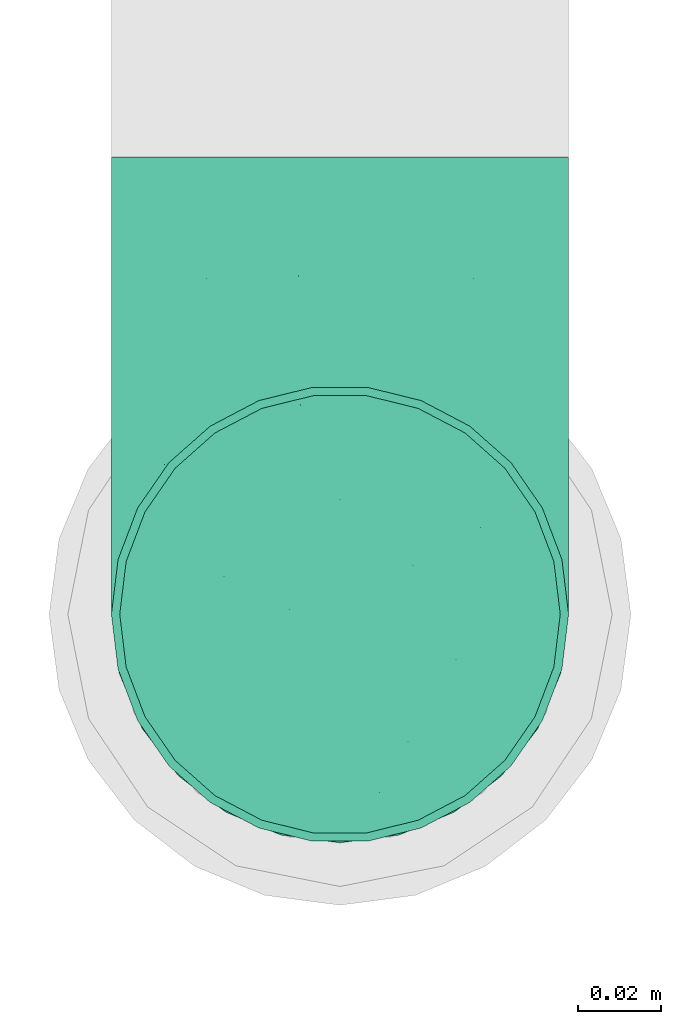
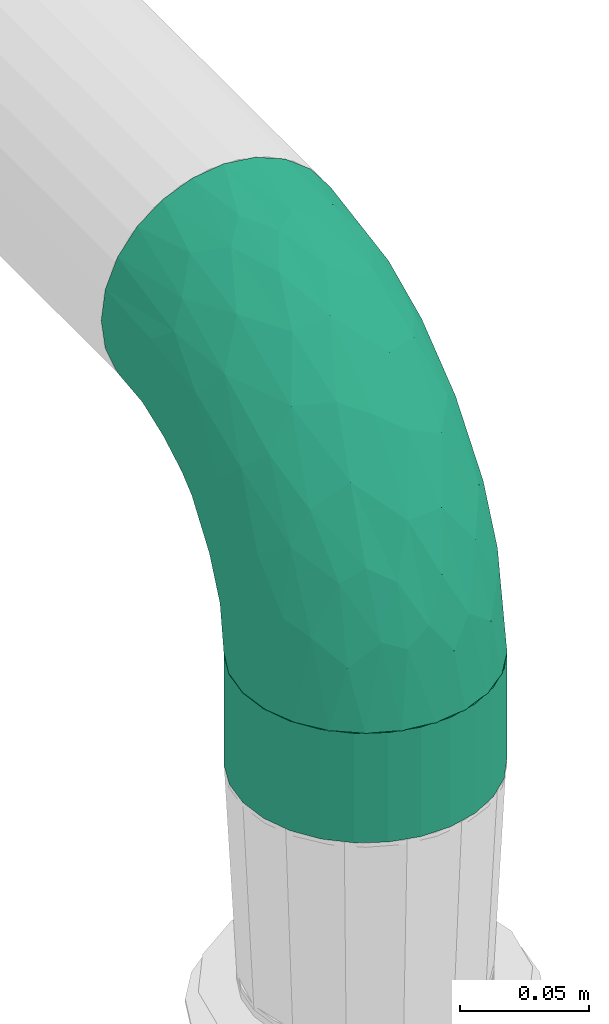
# One storey, part 47 of 115: 1 flow fitting, 1 flow segment.
"""IFC2X3 building model written with IfcOpenShell, lengths in millimetres."""

from ifc_helpers import new_model, entity, si_unit, converted_unit, derived_unit, direction, frame, origin_with_axes, origin_2d_with_axis, place, context, subcontext, project, spatial, hollow_circle, extrude, open_shell, surface_model, source, transform, mapped, material, layer, layer_set, layer_usage, type_object, element, save


model = new_model("IFC2X3")

# Units and contexts
model_context = context("Model", 3, precision=1e-05, world=origin_with_axes(), true_north=direction((0.0, 1.0)))
body_context = subcontext(model_context, "Body", "Model", "MODEL_VIEW")
ifc_project = project(units=[si_unit("AREAUNIT", "SQUARE_METRE"), si_unit("VOLUMEUNIT", "CUBIC_METRE", prefix="DECI"), si_unit("TIMEUNIT", "SECOND"), si_unit("THERMODYNAMICTEMPERATUREUNIT", "DEGREE_CELSIUS"), si_unit("PRESSUREUNIT", "PASCAL"), si_unit("MASSUNIT", "GRAM", prefix="KILO"), si_unit("LENGTHUNIT", "METRE", prefix="MILLI"), si_unit("POWERUNIT", "WATT"), si_unit("ELECTRICCURRENTUNIT", "AMPERE"), si_unit("ELECTRICVOLTAGEUNIT", "VOLT"), derived_unit("VOLUMETRICFLOWRATEUNIT", [(si_unit("VOLUMEUNIT", "CUBIC_METRE", prefix="DECI"), 1), (si_unit("TIMEUNIT", "SECOND"), -1)]), derived_unit("LINEARVELOCITYUNIT", [(si_unit("LENGTHUNIT", "METRE"), 1), (si_unit("TIMEUNIT", "SECOND"), -1)]), derived_unit("MASSDENSITYUNIT", [(si_unit("MASSUNIT", "GRAM", prefix="KILO"), 1), (si_unit("VOLUMEUNIT", "CUBIC_METRE"), -1)]), converted_unit("PLANEANGLEUNIT", "DEGREE", entity("IfcRatioMeasure", 0.01745), si_unit("PLANEANGLEUNIT", "RADIAN"), dimensions=[0, 0, 0, 0, 0, 0, 0])], contexts=[model_context])

# Site, building, storey
site_placement = place(None, origin_with_axes())
site = spatial("IfcSite", under=ifc_project, at=site_placement, CompositionType="ELEMENT")
building_placement = place(site_placement, origin_with_axes())
building = spatial("IfcBuilding", under=site, at=building_placement, Name="mc-building", CompositionType="ELEMENT")
storey_placement = place(building_placement, frame((0.0, 0.0, 2950.0), z_axis=(0.0, 0.0, 1.0), x_axis=(1.0, 0.0, 0.0)))
storey = spatial("IfcBuildingStorey", under=building, at=storey_placement, Name="2. Korrus", CompositionType="ELEMENT", Elevation=2950.0)

# Flow segment
ifc_material = material(Name="FZ1")
ifc_layer = layer(ifc_material, 0.0)
ifc_layer_set = layer_set([ifc_layer], Name="FZ1")
ifc_layer_usage = layer_usage(ifc_layer_set, "AXIS1", "POSITIVE", 0.0)
duct_segment_type = type_object("IfcDuctSegmentType", PredefinedType="RIGIDSEGMENT")
shared_shape_1 = source(origin_with_axes(), body_context, "Body", "SweptSolid", [
    extrude(hollow_circle(Radius=55.0, WallThickness=2.0, at=origin_2d_with_axis()), frame((0.0, 0.0, 0.0), z_axis=(1.0, 0.0, 0.0), x_axis=(0.0, 1.0, 0.0)), (0.0, 0.0, 1.0), 51.9),
])
flow_segment_placement = place(storey_placement, frame((11458.64544, 8183.57591, 2355.0), z_axis=(0.0, 1.0, 0.0), x_axis=(0.0, 0.0, -1.0)))
element("IfcFlowSegment", 1, at=flow_segment_placement, inside=storey, type_object=duct_segment_type, material=ifc_layer_usage, context=body_context, shape_type="MappedRepresentation", body=[
    mapped(shared_shape_1, transform((0.0, 0.0, 0.0), scale=1.0)),
])

# Flow fitting
duct_fitting_type = type_object("IfcDuctFittingType", Name="BU", PredefinedType="BEND")
shared_shape_2 = source(origin_with_axes(), body_context, "Body", "SurfaceModel", [
    surface_model("IfcShellBasedSurfaceModel", [(-110.0, 0.0, -55.0), (-110.0, -14.23505, -53.12592), (-110.0, 14.23505, -53.12592), (-110.0, 53.12592, 14.23505), (-110.0, 27.5, -47.63139), (-110.0, 38.89087, -38.89087), (-110.0, -55.0, 0.0), (-110.0, -53.12592, 14.23505), (-110.0, -38.89087, -38.89087), (-110.0, -27.5, -47.63139), (-110.0, -53.12592, -14.23505), (-110.0, -47.63139, -27.5), (-110.0, -14.23505, 53.12592), (-110.0, 14.23505, 53.12592), (-110.0, 27.5, 47.63139), (-110.0, -47.63139, 27.5), (-110.0, -38.89087, 38.89087), (-110.0, -27.5, 47.63139), (-110.0, 0.0, 55.0), (-110.0, 55.0, 0.0), (-110.0, 53.12592, -14.23505), (-110.0, 47.63139, -27.5), (-110.0, 47.63139, 27.5), (-110.0, 38.89087, 38.89087), (-14.23505, 110.0, -53.12592), (-55.0, 110.0, 0.0), (0.0, 110.0, -55.0), (-27.5, 110.0, -47.63139), (-38.89087, 110.0, -38.89087), (-47.63139, 110.0, -27.5), (38.89087, 110.0, -38.89087), (53.12592, 110.0, 14.23505), (27.5, 110.0, -47.63139), (14.23505, 110.0, -53.12592), (47.63139, 110.0, -27.5), (53.12592, 110.0, -14.23505), (55.0, 110.0, 0.0), (-53.12592, 110.0, -14.23505), (-53.12592, 110.0, 14.23505), (-47.63139, 110.0, 27.5), (-38.89087, 110.0, 38.89087), (-27.5, 110.0, 47.63139), (0.0, 110.0, 55.0), (-14.23505, 110.0, 53.12592), (38.89087, 110.0, 38.89087), (47.63139, 110.0, 27.5), (27.5, 110.0, 47.63139), (14.23505, 110.0, 53.12592), (-64.21732, 48.68956, 43.63444), (-76.6405, 38.18013, 45.55988), (-60.44912, 32.56953, 51.94617), (-76.00813, 5.38378, 55.0), (-90.15553, 11.94394, 54.09138), (-78.5998, 26.77405, 50.81338), (-70.18771, 18.55163, 54.03432), (-75.55424, 54.2118, 32.41257), (-93.27622, 45.77614, 33.48188), (-96.12334, 22.13664, 50.81337), (-21.00813, 45.34362, 55.0), (-18.36258, 70.48427, 54.04484), (-32.04182, 59.64019, 52.24446), (-63.88653, 74.77858, 17.99134), (-74.66383, 63.08407, 19.92123), (-63.60674, 66.07878, 29.97482), (-99.597, 52.72185, 18.52927), (-93.11138, 56.59448, 10.50359), (-98.21577, 57.34403, 0.0), (-53.42855, 92.60092, 21.04759), (-88.54852, 54.8376, 21.04759), (-11.86161, 90.23965, 54.10313), (-5.38378, 76.00813, 55.0), (-57.34403, 98.21577, 0.0), (-56.64619, 93.12774, 10.22088), (-45.34362, 21.00813, 55.0), (-44.60838, 44.60838, 52.13415), (-92.68484, 35.46673, 43.63443), (-22.25266, 95.40765, 50.81337), (-35.97783, 90.61597, 43.63443), (-43.70931, 69.58671, 44.47149), (-27.23711, 77.39884, 50.81337), (-57.2828, 79.3123, 24.9774), (-58.67786, 84.31125, 16.04456), (-82.93277, 60.36161, 12.91784), (-49.88337, 54.51816, 47.224), (-74.57753, 66.83759, 9.55742), (-45.35812, 94.97281, 33.48188), (-59.18663, 88.95241, 0.0), (-51.517, 78.6292, 33.48188), (-65.14788, 80.03077, 0.0), (-56.45322, 62.06476, 39.63545), (-88.95241, 59.18663, 0.0), (-71.10913, 71.10913, 0.0), (-80.03077, 65.14788, 0.0), (-94.9309, 45.36788, -33.48188), (-93.11358, 56.60141, -10.46614), (-99.64997, 52.79499, -18.30015), (-90.20425, 36.08686, -43.63443), (-79.99933, 46.56772, -37.92748), (-76.00813, 5.38378, -55.0), (-72.75364, 19.68651, -53.60527), (-45.34362, 21.00813, -55.0), (-21.91957, 65.12078, -53.85897), (-5.38378, 76.00813, -55.0), (-21.00813, 45.34362, -55.0), (-35.41876, 92.89265, -43.63443), (-91.10309, 11.02766, -54.21832), (-45.77614, 93.27622, -33.48188), (-90.50474, 23.21022, -50.81337), (-70.92854, 33.31794, -49.51754), (-78.52933, 63.35627, -11.73997), (-24.91508, 84.05606, -50.81337), (-88.78941, 54.74452, -21.04759), (-69.59921, 57.34866, -33.48187), (-73.36422, 62.46673, -22.94182), (-63.49062, 67.59111, -28.46929), (-56.59448, 93.11138, -10.50359), (-54.8376, 88.54852, -21.04759), (-54.10679, 75.85581, -32.31867), (-57.75956, 31.09612, -52.80882), (-52.72185, 99.597, -18.52927), (-12.62913, 89.46304, -53.99097), (-34.46825, 66.46123, -50.04329), (-43.9837, 43.9837, -52.42279), (-65.78527, 72.58348, -17.68796), (-70.34468, 43.65295, -44.21951), (-57.47001, 51.99467, -44.91465), (-60.72547, 82.29174, -12.88567), (-42.34915, 74.24548, -43.63444), (-57.25194, 63.5016, -38.08211), (-80.95344, 53.56991, -29.32027), (-52.32891, 4.55257, -54.0482), (32.52942, 47.13398, -30.48571), (14.88266, 20.92917, -33.7947), (14.95561, 36.05775, -42.26543), (30.24048, 70.09027, -41.7461), (19.3559, 65.35825, -48.00507), (-70.35075, -46.44478, -19.5952), (-47.13398, -32.52942, -30.48571), (-28.49299, -30.5778, -16.4009), (-4.55257, 52.32891, -54.0482), (-22.4954, 22.4954, -53.25347), (-75.47368, -11.22546, -52.60718), (-81.32209, -51.5606, -9.98467), (-80.81763, -41.84862, -32.14655), (-70.09027, -30.24048, -41.7461), (-36.05774, -14.95561, -42.26543), (-9.15831, -10.852, -27.8997), (-65.35825, -19.3559, -48.00507), (11.22546, 75.47368, -52.60718), (3.94376, 43.9333, -50.53315), (-13.39742, 13.39743, -48.13058), (-43.9333, -3.94376, -50.53315), (49.37776, 67.29486, 0.0), (41.8609, 47.82256, -9.92641), (50.20582, 74.51695, -9.9731), (18.93131, 11.7156, -17.56239), (-27.5, -32.89419, 0.0), (-1.23348, -12.25375, -12.18106), (41.84862, 80.81763, -32.14655), (35.70604, 41.31408, -20.38235), (46.44478, 70.35075, -19.5952), (32.89419, 27.5, 0.0), (6.67262, -6.67262, 0.0), (-67.29486, -49.37776, 0.0), (-50.36265, -42.95545, -9.51562), (-5.47251, 5.47251, -39.92906), (-70.35075, -46.44478, 19.5952), (-74.51695, -50.20582, 9.9731), (-41.31407, -35.70604, 20.38235), (-47.13398, -32.52942, 30.48571), (-80.81763, -41.84862, 32.14655), (-4.55257, 52.32891, 54.0482), (11.22546, 75.47368, 52.60718), (-43.9333, -3.94376, 50.53315), (-65.35825, -19.3559, 48.00507), (-36.05774, -14.95561, 42.26543), (-70.09027, -30.24048, 41.7461), (-11.7156, -18.93131, 17.56239), (30.5778, 28.49299, 16.4009), (12.25375, 1.23348, 12.18106), (51.5606, 81.32209, 9.98467), (42.95545, 50.36265, 9.51562), (-75.47368, -11.22546, 52.60718), (-52.32891, 4.55257, 54.0482), (3.94376, 43.9333, 50.53315), (-22.4954, 22.4954, 53.25347), (-13.39742, 13.39743, 48.13058), (10.852, 9.15831, 27.8997), (-20.92916, -14.88266, 33.79469), (-47.82256, -41.8609, 9.92641), (32.52942, 47.13398, 30.48571), (46.44478, 70.35075, 19.5952), (41.84862, 80.81763, 32.14655), (30.24048, 70.09027, 41.7461), (19.3559, 65.35825, 48.00507), (14.95561, 36.05775, 42.26543), (-5.47251, 5.47251, 39.92906)], [open_shell([[[0, 1, 2]], [[2, 3, 4]], [[4, 3, 5]], [[2, 6, 7]], [[8, 6, 9]], [[1, 9, 6]], [[10, 6, 11]], [[8, 11, 6]], [[6, 2, 1]], [[12, 13, 14]], [[15, 2, 7]], [[16, 17, 2]], [[2, 17, 12]], [[12, 18, 13]], [[19, 20, 3]], [[5, 3, 21]], [[20, 21, 3]], [[22, 3, 2]], [[23, 22, 2]], [[12, 14, 2]], [[2, 14, 23]], [[15, 16, 2]], [[24, 25, 26]], [[27, 25, 24]], [[25, 28, 29]], [[28, 25, 27]], [[30, 26, 31]], [[26, 30, 32]], [[32, 33, 26]], [[34, 31, 35]], [[31, 34, 30]], [[35, 31, 36]], [[29, 37, 25]], [[38, 39, 26]], [[39, 40, 26]], [[41, 42, 40]], [[42, 26, 40]], [[42, 41, 43]], [[26, 44, 45]], [[31, 26, 45]], [[26, 46, 44]], [[47, 46, 26]], [[42, 47, 26]], [[25, 38, 26]], [[48, 49, 50]], [[18, 51, 52]], [[53, 54, 50]], [[55, 56, 49]], [[56, 22, 23]], [[13, 57, 14]], [[58, 59, 60]], [[61, 62, 63]], [[3, 64, 65]], [[53, 52, 54]], [[3, 65, 66]], [[67, 39, 38]], [[56, 68, 64]], [[65, 64, 68]], [[69, 59, 70]], [[38, 71, 72]], [[73, 58, 74]], [[75, 49, 56]], [[76, 69, 43]], [[53, 57, 52]], [[77, 78, 79]], [[41, 76, 43]], [[43, 69, 42]], [[55, 68, 56]], [[23, 14, 75]], [[76, 77, 79]], [[80, 67, 81]], [[62, 82, 68]], [[60, 78, 83]], [[62, 84, 82]], [[85, 77, 40]], [[81, 67, 72]], [[86, 72, 71]], [[87, 85, 67]], [[61, 81, 88]], [[77, 41, 40]], [[78, 77, 87]], [[23, 75, 56]], [[83, 89, 48]], [[85, 40, 39]], [[62, 68, 55]], [[89, 87, 63]], [[83, 48, 50]], [[57, 75, 14]], [[49, 75, 53]], [[67, 85, 39]], [[87, 77, 85]], [[63, 62, 55]], [[89, 55, 48]], [[80, 63, 87]], [[66, 65, 90]], [[66, 19, 3]], [[84, 91, 92]], [[92, 90, 82]], [[65, 82, 90]], [[61, 84, 62]], [[92, 82, 84]], [[68, 82, 65]], [[3, 22, 64]], [[56, 64, 22]], [[38, 25, 71]], [[81, 72, 86]], [[38, 72, 67]], [[91, 61, 88]], [[80, 81, 61]], [[63, 80, 61]], [[67, 80, 87]], [[77, 76, 41]], [[79, 59, 69]], [[79, 69, 76]], [[42, 69, 70]], [[60, 59, 79]], [[58, 70, 59]], [[78, 60, 79]], [[58, 60, 74]], [[52, 57, 13]], [[75, 57, 53]], [[18, 52, 13]], [[52, 51, 54]], [[51, 73, 54]], [[50, 73, 74]], [[73, 50, 54]], [[50, 74, 83]], [[60, 83, 74]], [[89, 83, 78]], [[87, 89, 78]], [[55, 89, 63]], [[50, 49, 53]], [[55, 49, 48]], [[81, 86, 88]], [[91, 84, 61]], [[5, 21, 93]], [[90, 94, 66]], [[20, 94, 95]], [[96, 93, 97]], [[98, 99, 100]], [[96, 4, 5]], [[101, 102, 103]], [[28, 27, 104]], [[2, 105, 0]], [[104, 106, 28]], [[99, 105, 107]], [[108, 107, 96]], [[90, 109, 94]], [[107, 2, 4]], [[20, 66, 94]], [[27, 24, 110]], [[109, 111, 94]], [[112, 113, 114]], [[37, 115, 71]], [[116, 106, 117]], [[99, 118, 100]], [[116, 115, 119]], [[37, 119, 115]], [[24, 120, 110]], [[121, 110, 101]], [[119, 106, 116]], [[101, 110, 120]], [[122, 103, 100]], [[117, 123, 116]], [[124, 125, 108]], [[115, 116, 126]], [[106, 29, 28]], [[26, 102, 120]], [[127, 104, 110]], [[97, 124, 96]], [[125, 122, 118]], [[128, 127, 125]], [[96, 5, 93]], [[115, 126, 86]], [[117, 106, 127]], [[111, 113, 129]], [[95, 93, 21]], [[97, 129, 112]], [[110, 104, 27]], [[106, 104, 127]], [[96, 107, 4]], [[99, 107, 108]], [[99, 108, 118]], [[105, 99, 98]], [[112, 114, 128]], [[121, 125, 127]], [[20, 19, 66]], [[109, 90, 92]], [[94, 111, 95]], [[91, 123, 109]], [[129, 113, 112]], [[93, 95, 111]], [[21, 20, 95]], [[71, 115, 86]], [[71, 25, 37]], [[123, 91, 88]], [[126, 116, 123]], [[123, 88, 126]], [[86, 126, 88]], [[37, 29, 119]], [[106, 119, 29]], [[129, 93, 111]], [[124, 112, 125]], [[0, 105, 98]], [[107, 105, 2]], [[125, 118, 108]], [[100, 118, 122]], [[93, 129, 97]], [[113, 111, 109]], [[109, 123, 113]], [[114, 123, 117]], [[123, 114, 113]], [[128, 114, 117]], [[127, 128, 117]], [[112, 128, 125]], [[103, 122, 101]], [[110, 121, 127]], [[101, 122, 121]], [[125, 121, 122]], [[26, 120, 24]], [[101, 120, 102]], [[96, 124, 108]], [[92, 91, 109]], [[112, 124, 97]], [[100, 130, 98]], [[131, 132, 133]], [[32, 134, 135]], [[136, 137, 138]], [[139, 140, 103]], [[98, 141, 0]], [[142, 10, 136]], [[143, 144, 137]], [[6, 10, 142]], [[137, 145, 146]], [[144, 147, 145]], [[143, 136, 11]], [[11, 136, 10]], [[8, 143, 11]], [[148, 149, 139]], [[8, 9, 144]], [[9, 1, 147]], [[130, 141, 98]], [[103, 140, 100]], [[148, 135, 149]], [[150, 151, 140]], [[152, 153, 154]], [[130, 140, 151]], [[148, 26, 33]], [[147, 1, 141]], [[155, 146, 132]], [[156, 138, 157]], [[134, 30, 158]], [[150, 140, 149]], [[158, 30, 34]], [[30, 134, 32]], [[153, 159, 160]], [[131, 160, 159]], [[144, 145, 137]], [[36, 152, 154]], [[146, 138, 137]], [[155, 161, 162]], [[158, 160, 131]], [[133, 149, 135]], [[156, 163, 164]], [[163, 142, 164]], [[139, 103, 102]], [[153, 152, 161]], [[34, 35, 160]], [[162, 157, 155]], [[132, 165, 133]], [[157, 146, 155]], [[140, 130, 100]], [[141, 130, 151]], [[141, 151, 147]], [[141, 1, 0]], [[102, 26, 148]], [[140, 139, 149]], [[102, 148, 139]], [[135, 33, 32]], [[151, 150, 145]], [[9, 147, 144]], [[151, 145, 147]], [[145, 165, 146]], [[135, 148, 33]], [[133, 135, 134]], [[131, 133, 134]], [[133, 165, 150]], [[133, 150, 149]], [[145, 150, 165]], [[132, 131, 159]], [[146, 165, 132]], [[160, 158, 34]], [[134, 158, 131]], [[144, 143, 8]], [[136, 143, 137]], [[155, 153, 161]], [[154, 153, 160]], [[153, 155, 159]], [[132, 159, 155]], [[160, 35, 154]], [[36, 154, 35]], [[164, 136, 138]], [[6, 142, 163]], [[136, 164, 142]], [[156, 164, 138]], [[156, 157, 162]], [[146, 157, 138]], [[15, 7, 166]], [[6, 163, 167]], [[168, 169, 166]], [[166, 169, 170]], [[171, 172, 70]], [[173, 174, 175]], [[17, 176, 174]], [[177, 156, 162]], [[176, 16, 170]], [[170, 16, 15]], [[161, 178, 179]], [[152, 180, 181]], [[182, 173, 183]], [[18, 12, 182]], [[184, 185, 186]], [[183, 185, 73]], [[183, 73, 51]], [[177, 187, 188]], [[189, 168, 166]], [[187, 178, 190]], [[16, 176, 17]], [[161, 152, 181]], [[45, 191, 31]], [[45, 44, 192]], [[192, 191, 45]], [[180, 36, 31]], [[193, 194, 195]], [[46, 47, 194]], [[193, 195, 190]], [[193, 44, 46]], [[172, 42, 70]], [[185, 58, 73]], [[189, 163, 156]], [[163, 189, 167]], [[70, 58, 171]], [[184, 171, 185]], [[169, 188, 175]], [[180, 31, 191]], [[192, 193, 190]], [[191, 190, 178]], [[182, 174, 173]], [[194, 47, 172]], [[190, 195, 187]], [[186, 185, 173]], [[162, 179, 177]], [[188, 196, 175]], [[179, 187, 177]], [[185, 171, 58]], [[172, 171, 184]], [[172, 184, 194]], [[172, 47, 42]], [[51, 18, 182]], [[185, 183, 173]], [[51, 182, 183]], [[174, 12, 17]], [[184, 186, 195]], [[46, 194, 193]], [[184, 195, 194]], [[195, 196, 187]], [[174, 182, 12]], [[175, 174, 176]], [[169, 175, 176]], [[175, 196, 186]], [[175, 186, 173]], [[195, 186, 196]], [[188, 169, 168]], [[187, 196, 188]], [[166, 170, 15]], [[176, 170, 169]], [[193, 192, 44]], [[191, 192, 190]], [[177, 189, 156]], [[167, 189, 166]], [[189, 177, 168]], [[188, 168, 177]], [[166, 7, 167]], [[6, 167, 7]], [[181, 191, 178]], [[36, 180, 152]], [[191, 181, 180]], [[161, 181, 178]], [[161, 179, 162]], [[187, 179, 178]]])]),
])
flow_fitting_placement = place(storey_placement, frame((11458.64544, 8183.57591, 2465.0), z_axis=(1.0, 0.0, 0.0), x_axis=(0.0, -1.0, 0.0)))
element("IfcFlowFitting", 2, at=flow_fitting_placement, inside=storey, type_object=duct_fitting_type, Name="BU", context=body_context, shape_type="MappedRepresentation", body=[
    mapped(shared_shape_2, transform((0.0, 0.0, 0.0), scale=1.0)),
])

save(model, "model.ifc")
